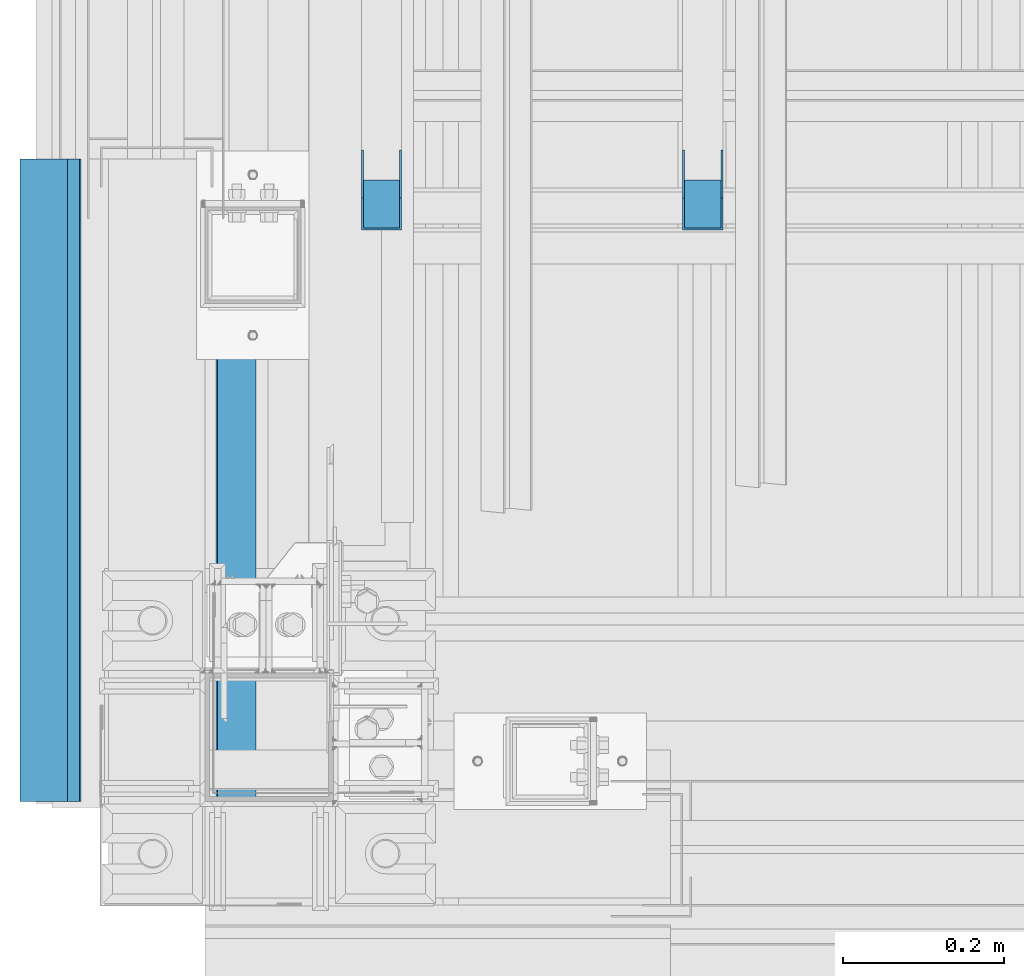
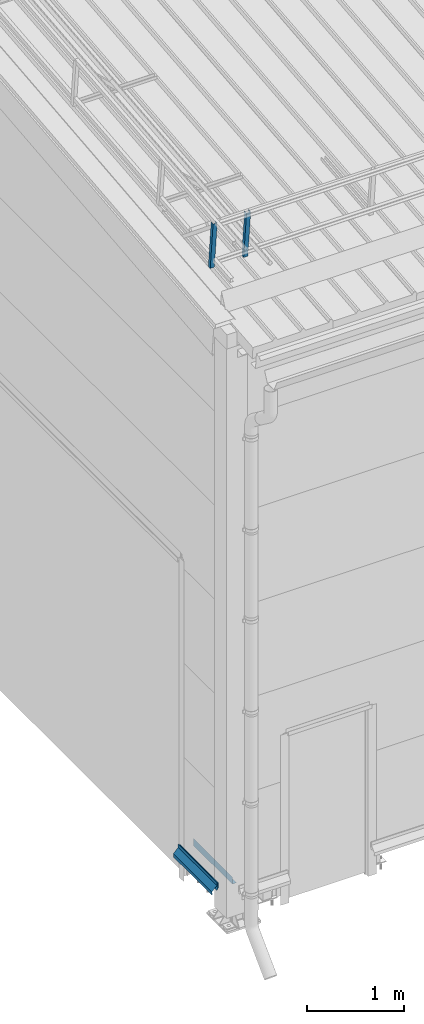
# One storey, part 85 of 709: 3 beams, 2 members, 5 elements without a shape of their own.
"""IFC4 building model written with IfcOpenShell, lengths in millimetres."""

from ifc_helpers import new_model, si_unit, direction, frame, origin_with_axes, place, context, subcontext, project, spatial, line, indexed_curve, outline, extrude, material, element, aggregate, save


model = new_model("IFC4")

# Units and contexts
model_context = context("Model", 3, precision=0.2, world=origin_with_axes(), true_north=direction((0.0, 1.0)))
body_context = subcontext(model_context, "Body", "Model", "MODEL_VIEW")
ifc_project = project(units=[si_unit("LENGTHUNIT", "METRE", prefix="MILLI"), si_unit("AREAUNIT", "SQUARE_METRE"), si_unit("VOLUMEUNIT", "CUBIC_METRE"), si_unit("MASSUNIT", "GRAM", prefix="KILO"), si_unit("TIMEUNIT", "SECOND"), si_unit("PLANEANGLEUNIT", "RADIAN"), si_unit("SOLIDANGLEUNIT", "STERADIAN"), si_unit("THERMODYNAMICTEMPERATUREUNIT", "DEGREE_CELSIUS"), si_unit("LUMINOUSINTENSITYUNIT", "LUMEN")], contexts=[model_context])

# Site, building, storey
site_placement = place(None, origin_with_axes())
site = spatial("IfcSite", under=ifc_project, at=site_placement, CompositionType="ELEMENT")
building_placement = place(site_placement, origin_with_axes())
building = spatial("IfcBuilding", under=site, at=building_placement, Name="Undefined", CompositionType="ELEMENT")
storey_placement = place(building_placement, origin_with_axes())
storey = spatial("IfcBuildingStorey", under=building, at=storey_placement, Name="Undefined", CompositionType="ELEMENT", Elevation=0.0)

# Assembly, member
assembly_1_placement = place(storey_placement, frame((220.0, 790.8138, 7559.25124), z_axis=(0.0, 0.9950371902, 0.099503719), x_axis=(0.0, -0.099503719, 0.9950371902)))
assembly_1 = element("IfcElementAssembly", 1, at=assembly_1_placement, inside=storey)
ifc_material = material(Name="Steel_Undefined", Category="STEEL")
member_1_placement = place(assembly_1_placement, origin_with_axes())
member_1 = element("IfcMember", 2, at=member_1_placement, material=ifc_material, ObjectType="602", context=body_context, shape_type="SolidModel", body=[
    extrude(outline(indexed_curve([(-20.0, -25.0), (20.0, -25.0), (20.0, -22.5), (-17.5, -22.5), (-17.5, 22.5), (20.0, 22.5), (20.0, 25.0), (-20.0, 25.0)], segments=[line(1, 2, 3, 4, 5, 6, 7, 8, 1)])), frame((0.0, 0.0, 0.0), z_axis=(-1.0, 0.0, 0.0), x_axis=(0.0, 0.0, 1.0)), (0.0, 0.0, -1.0), 600.0),
])
aggregate(assembly_1, [member_1])

assembly_2_placement = place(storey_placement, frame((620.0, 790.8138, 7559.25124), z_axis=(0.0, 0.9950371902, 0.099503719), x_axis=(0.0, -0.099503719, 0.9950371902)))
assembly_2 = element("IfcElementAssembly", 3, at=assembly_2_placement, inside=storey)
member_2_placement = place(assembly_2_placement, origin_with_axes())
member_2 = element("IfcMember", 4, at=member_2_placement, material=ifc_material, ObjectType="602", context=body_context, shape_type="SolidModel", body=[
    extrude(outline(indexed_curve([(-20.0, -25.0), (20.0, -25.0), (20.0, -22.5), (-17.5, -22.5), (-17.5, 22.5), (20.0, 22.5), (20.0, 25.0), (-20.0, 25.0)], segments=[line(1, 2, 3, 4, 5, 6, 7, 8, 1)])), frame((0.0, 0.0, 0.0), z_axis=(-1.0, 0.0, 0.0), x_axis=(0.0, 0.0, 1.0)), (0.0, 0.0, -1.0), 600.0),
])
aggregate(assembly_2, [member_2])

# Assembly, beam
assembly_3_placement = place(storey_placement, frame((-170.375, 0.0, 370.0), z_axis=(1.0, 0.0, 0.0), x_axis=(0.0, 1.0, 0.0)))
assembly_3 = element("IfcElementAssembly", 5, at=assembly_3_placement, inside=storey)
beam_1_placement = place(assembly_3_placement, origin_with_axes())
beam_1 = element("IfcBeam", 6, at=beam_1_placement, material=ifc_material, context=body_context, shape_type="SolidModel", body=[
    extrude(outline(indexed_curve([(0.375, -20.0), (0.375, 19.25), (0.495, 19.25), (0.495, 5.0), (1.245, 5.0), (1.245, 20.0), (-0.375, 20.0), (-0.375, -19.68934), (-59.625, -78.93934), (-59.625, -118.93934), (-52.125, -105.94896), (-52.77452, -105.57396), (-58.875, -116.1403), (-58.875, -79.25)], segments=[line(1, 2, 3, 4, 5, 6, 7, 8, 9, 10, 11, 12, 13, 14, 1)])), frame((0.0, 0.0, 0.0), z_axis=(-1.0, 0.0, 0.0), x_axis=(0.0, 0.0, 1.0)), (0.0, 0.0, -1.0), 800.0),
])
aggregate(assembly_3, [beam_1])

assembly_4_placement = place(storey_placement, frame((-155.0, 800.0, 350.0), z_axis=(0.0, 0.0, -1.0), x_axis=(0.0, -1.0, 0.0)))
assembly_4 = element("IfcElementAssembly", 7, at=assembly_4_placement, inside=storey)
beam_2_placement = place(assembly_4_placement, origin_with_axes())
beam_2 = element("IfcBeam", 8, at=beam_2_placement, material=ifc_material, context=body_context, shape_type="SolidModel", body=[
    extrude(outline(indexed_curve([(-35.0, -1.0), (35.0, -1.0), (60.98076, 14.0), (59.98076, 15.73205), (34.4641, 1.0), (-35.0, 1.0)], segments=[line(1, 2, 3, 4, 5, 6, 1)])), frame((0.0, 0.0, 0.0), z_axis=(-1.0, 0.0, 0.0), x_axis=(0.0, 0.0, 1.0)), (0.0, 0.0, -1.0), 800.0),
])
aggregate(assembly_4, [beam_2])

assembly_5_placement = place(storey_placement, frame((15.0, 0.0, 350.0), z_axis=(0.0, 0.0, -1.0), x_axis=(0.0, 1.0, 0.0)))
assembly_5 = element("IfcElementAssembly", 9, at=assembly_5_placement, inside=storey)
beam_3_placement = place(assembly_5_placement, origin_with_axes())
beam_3 = element("IfcBeam", 10, at=beam_3_placement, material=ifc_material, context=body_context, shape_type="SolidModel", body=[
    extrude(outline(indexed_curve([(-45.0, -1.0), (45.0, -1.0), (45.0, 49.0), (43.0, 49.0), (43.0, 1.0), (-45.0, 1.0)], segments=[line(1, 2, 3, 4, 5, 6, 1)])), frame((0.0, 0.0, 0.0), z_axis=(-1.0, 0.0, 0.0), x_axis=(0.0, 0.0, 1.0)), (0.0, 0.0, -1.0), 800.0),
])
aggregate(assembly_5, [beam_3])

save(model, "model.ifc")
